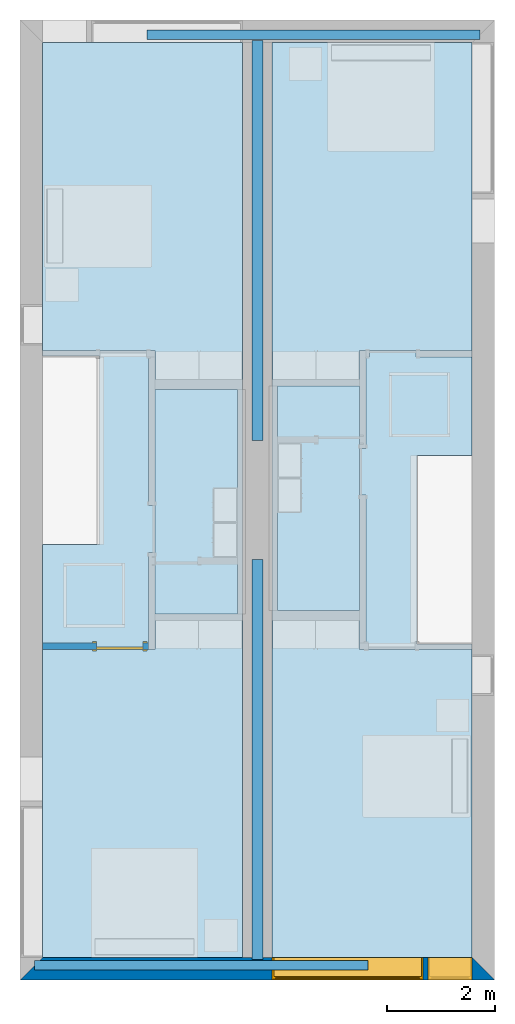
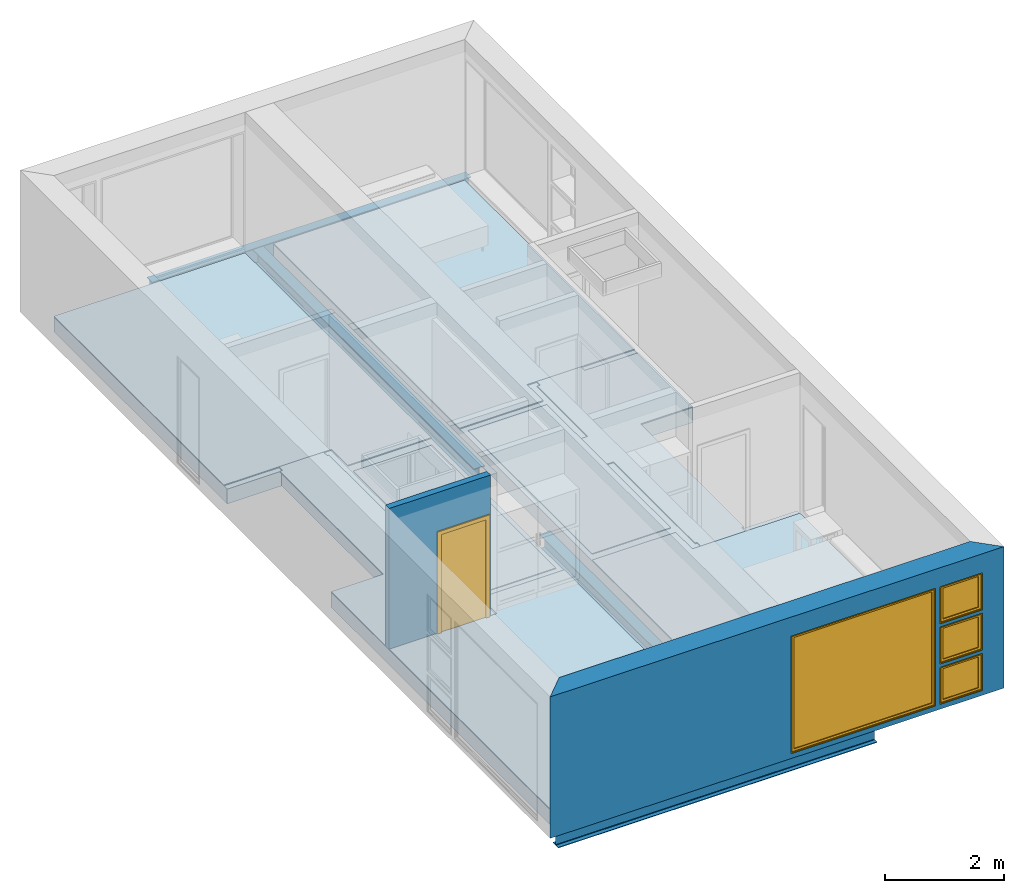
# One storey, part 1 of 10: 10 slabs, 4 beams, 4 windows, 2 walls, 1 door, 6 openings.
"""IFC2X3 building model written with IfcOpenShell, lengths in metres."""

from ifc_helpers import new_model, entity, si_unit, converted_unit, derived_unit, direction, frame, frame_2d, origin, origin_2d_with_axis, place, context, subcontext, project, spatial, polyline, rectangle, i_section, outline, extrude, source, transform, mapped, material, material_list, layer, layer_set, layer_usage, type_object, type_shapes, element, fill, save


model = new_model("IFC2X3")

# Units and contexts
model_context = context("Model", 3, precision=1e-05, world=origin(), true_north=direction((6.12303176911189e-17, 1.0)))
body_context = subcontext(model_context, "Body", "Model", "MODEL_VIEW")
ifc_project = project(units=[derived_unit("USERDEFINED", [(si_unit("LENGTHUNIT", "METRE"), -2), (si_unit("TIMEUNIT", "SECOND"), -2), (si_unit("MASSUNIT", "GRAM", prefix="KILO"), 1)]), si_unit("FREQUENCYUNIT", "HERTZ"), si_unit("LENGTHUNIT", "METRE"), si_unit("ILLUMINANCEUNIT", "LUX"), derived_unit("LINEARVELOCITYUNIT", [(si_unit("TIMEUNIT", "SECOND"), -1), (si_unit("LENGTHUNIT", "METRE"), 1)]), si_unit("POWERUNIT", "WATT"), si_unit("LUMINOUSINTENSITYUNIT", "CANDELA"), si_unit("AREAUNIT", "SQUARE_METRE"), si_unit("VOLUMEUNIT", "CUBIC_METRE"), si_unit("ELECTRICVOLTAGEUNIT", "VOLT"), si_unit("PRESSUREUNIT", "PASCAL"), converted_unit("PLANEANGLEUNIT", "DEGREE", entity("IfcRatioMeasure", 0.0174532925199433), si_unit("PLANEANGLEUNIT", "RADIAN"), dimensions=[0, 0, 0, 0, 0, 0, 0]), si_unit("THERMODYNAMICTEMPERATUREUNIT", "DEGREE_CELSIUS"), si_unit("MASSUNIT", "GRAM", prefix="KILO"), derived_unit("VOLUMETRICFLOWRATEUNIT", [(si_unit("LENGTHUNIT", "METRE"), 3), (si_unit("TIMEUNIT", "SECOND"), -1)]), si_unit("TIMEUNIT", "SECOND"), si_unit("LUMINOUSFLUXUNIT", "LUMEN"), derived_unit("USERDEFINED", [(si_unit("LUMINOUSFLUXUNIT", "LUMEN"), 1), (si_unit("TIMEUNIT", "SECOND"), 3), (si_unit("MASSUNIT", "GRAM", prefix="KILO"), -1), (si_unit("LENGTHUNIT", "METRE"), -2)]), si_unit("FORCEUNIT", "NEWTON", prefix="KILO"), si_unit("ELECTRICCURRENTUNIT", "AMPERE"), derived_unit("THERMALTRANSMITTANCEUNIT", [(si_unit("TIMEUNIT", "SECOND"), -3), (si_unit("THERMODYNAMICTEMPERATUREUNIT", "KELVIN"), -1), (si_unit("MASSUNIT", "GRAM", prefix="KILO"), 1)])], contexts=[model_context])

# Site, building, storey
site_placement = place(None, origin())
site = spatial("IfcSite", under=ifc_project, at=site_placement, CompositionType="ELEMENT")
building_placement = place(site_placement, origin())
building = spatial("IfcBuilding", under=site, at=building_placement, CompositionType="ELEMENT")
storey_placement = place(building_placement, frame((0.0, 0.0, 3.10000000000038)))
storey = spatial("IfcBuildingStorey", under=building, at=storey_placement, Name="Level 2", CompositionType="ELEMENT", Elevation=3.10000000000038)

# Beams
ifc_material_1 = material(Name="Metal - Steel - 345 MPa")
beam_1_placement = place(storey_placement, frame((4.4, -10.0, 0.0), z_axis=(0.0, 0.0, 1.0), x_axis=(0.0, -1.0, 0.0)))
element("IfcBeam", 1, at=beam_1_placement, inside=storey, material=ifc_material_1, context=body_context, shape_type="SweptSolid", body=[
    extrude(i_section(OverallWidth=0.203, OverallDepth=0.303, WebThickness=0.00750000000000972, FlangeThickness=0.0131000000000008, FilletRadius=0.0199000000000001, at=frame_2d((8.04911692853238e-16, 5.41233724504764e-16), x_axis=(0.0, 1.0))), frame((0.0, 0.0, -0.151500000000005), z_axis=(1.0, 0.0, 0.0), x_axis=(0.0, 0.0, -1.0)), (0.0, 0.0, 1.0), 7.42129999999997),
])
beam_2_placement = place(storey_placement, frame((0.266612879575042, -17.523, 0.0)))
element("IfcBeam", 2, at=beam_2_placement, inside=storey, material=ifc_material_1, context=body_context, shape_type="SweptSolid", body=[
    extrude(i_section(OverallWidth=0.178000000000018, OverallDepth=0.407, WebThickness=0.00769999999947201, FlangeThickness=0.0128000000000003, FilletRadius=0.017200000000001, at=frame_2d((0.0, -3.24740234702858e-15), x_axis=(0.0, 1.0))), frame((0.0, 0.0, -0.203500000000006), z_axis=(1.0, 0.0, 0.0), x_axis=(0.0, 0.0, -1.0)), (0.0, 0.0, 1.0), 6.18188712042496),
])
beam_3_placement = place(storey_placement, frame((4.40000000000001, -7.79999999999999, 0.0), z_axis=(0.0, 0.0, 1.0), x_axis=(0.0, 1.0, 0.0)))
element("IfcBeam", 3, at=beam_3_placement, inside=storey, material=ifc_material_1, context=body_context, shape_type="SweptSolid", body=[
    extrude(i_section(OverallWidth=0.203, OverallDepth=0.303, WebThickness=0.00749999999999992, FlangeThickness=0.0131000000000008, FilletRadius=0.0199000000000001, at=frame_2d((8.04911692853238e-16, -8.18789480661053e-16), x_axis=(0.0, 1.0))), frame((0.0, 0.0, -0.151500000000005), z_axis=(1.0, 0.0, 0.0), x_axis=(0.0, 0.0, -1.0)), (0.0, 0.0, 1.0), 7.42129999999997),
])
beam_4_placement = place(storey_placement, frame((8.53338712042499, -0.277000000000043, 0.0), z_axis=(0.0, 0.0, 1.0), x_axis=(-1.0, 0.0, 0.0)))
element("IfcBeam", 4, at=beam_4_placement, inside=storey, material=ifc_material_1, context=body_context, shape_type="SweptSolid", body=[
    extrude(i_section(OverallWidth=0.178000000000039, OverallDepth=0.407, WebThickness=0.00769999999893593, FlangeThickness=0.0128000000000003, FilletRadius=0.0171999999999996, at=frame_2d((0.0, 4.85722573273506e-17), x_axis=(0.0, 1.0))), frame((0.0, 0.0, -0.203500000000006), z_axis=(1.0, 0.0, 0.0), x_axis=(0.0, 0.0, -1.0)), (0.0, 0.0, 1.0), 6.18188712042496),
])

# Slabs
ifc_material_2 = material(Name="Wood - Sheathing - plywood")
ifc_layer_1 = layer(ifc_material_2, 0.019)
ifc_material_3 = material(Name="Wood - Dimensional Lumber")
ifc_layer_2 = layer(ifc_material_3, 0.286)
ifc_layer_set_1 = layer_set([ifc_layer_1, ifc_layer_2], Name="Sol:Residential - Wood Joist with")
ifc_layer_usage_1 = layer_usage(ifc_layer_set_1, "AXIS3", "POSITIVE", 0.0)
slab_1_placement = place(storey_placement, origin())
element("IfcSlab", 5, at=slab_1_placement, inside=storey, material=ifc_layer_usage_1, Name="Sol:Residential - Wood Joist with", ObjectType="Sol:Residential - Wood Joist with", PredefinedType="FLOOR", context=body_context, shape_type="SweptSolid", body=[
    extrude(outline(polyline([(-8.94324999999998, -1.1906), (-1.28525, -1.1906), (-1.28525000000001, -0.136199999999979), (2.20574999999999, -0.136199999999973), (2.20575, -1.1906), (8.02275, -1.1906), (8.02274999999998, 2.5174), (-8.94324999999999, 2.51739999999997), (-8.94324999999998, -1.1906)])), frame((1.6076, -8.43975, 0.0), z_axis=(0.0, 0.0, -1.0), x_axis=(0.0, 1.0, 0.0)), (0.0, 0.0, 1.0), 0.305),
])
ifc_layer_usage_2 = layer_usage(ifc_layer_set_1, "AXIS3", "POSITIVE", 0.0)
slab_2_placement = place(storey_placement, origin())
element("IfcSlab", 6, at=slab_2_placement, inside=storey, material=ifc_layer_usage_2, Name="Sol:Residential - Wood Joist with", ObjectType="Sol:Residential - Wood Joist with", PredefinedType="FLOOR", context=body_context, shape_type="SweptSolid", body=[
    extrude(outline(polyline([(-8.02274999999998, -2.52489999999999), (8.94324999999999, -2.52489999999999), (8.94324999999998, 1.18310000000001), (1.28525, 1.1831), (1.28525, 0.158699999999999), (-2.20574999999999, 0.158699999999993), (-2.20575, 1.18309999999999), (-8.02274999999999, 1.18309999999998), (-8.02274999999998, -2.52489999999999)])), frame((7.19989999999999, -9.36025, 0.0), z_axis=(0.0, 0.0, -1.0), x_axis=(0.0, 1.0, 0.0)), (0.0, 0.0, 1.0), 0.305),
])
ifc_material_4 = material(Name="Wood - Flooring")
ifc_layer_3 = layer(ifc_material_4, 0.016)
ifc_material_5 = material(Name="Insulation / Thermal Barriers - Semi-rigid insulation")
ifc_layer_4 = layer(ifc_material_5, 0.003)
ifc_layer_set_2 = layer_set([ifc_layer_3, ifc_layer_4], Name="Sol:Finish Floor - Wood")
ifc_layer_usage_3 = layer_usage(ifc_layer_set_2, "AXIS3", "POSITIVE", 0.0)
slab_3_placement = place(storey_placement, origin())
element("IfcSlab", 7, at=slab_3_placement, inside=storey, material=ifc_layer_usage_3, Name="Sol:Finish Floor - Wood", ObjectType="Sol:Finish Floor - Wood", PredefinedType="FLOOR", context=body_context, shape_type="SweptSolid", body=[
    extrude(outline(polyline([(-1.723, -1.93233333333333), (3.986, -1.93233333333333), (3.98599999999999, 1.77566666666667), (-2.263, 1.77566666666666), (-2.263, 0.156666666666669), (-1.723, 0.156666666666669), (-1.723, -1.93233333333333)])), frame((2.34933333333333, -4.403, 0.0189999999998181), z_axis=(0.0, 0.0, -1.0), x_axis=(0.0, 1.0, 0.0)), (0.0, 0.0, 1.0), 0.019),
])
ifc_layer_usage_4 = layer_usage(ifc_layer_set_2, "AXIS3", "POSITIVE", 0.0)
slab_4_placement = place(storey_placement, origin())
element("IfcSlab", 8, at=slab_4_placement, inside=storey, material=ifc_layer_usage_4, Name="Sol:Finish Floor - Wood", ObjectType="Sol:Finish Floor - Wood", PredefinedType="FLOOR", context=body_context, shape_type="SweptSolid", body=[
    extrude(outline(polyline([(-2.26299999999999, -1.77566666666667), (3.98599999999999, -1.77566666666667), (3.98599999999998, 1.93233333333333), (-1.723, 1.93233333333332), (-1.72299999999999, -0.156666666666655), (-2.26299999999999, -0.156666666666655), (-2.26299999999999, -1.77566666666667)])), frame((6.45066666666667, -4.40300000000001, 0.0189999999998181), z_axis=(0.0, 0.0, -1.0), x_axis=(0.0, 1.0, 0.0)), (0.0, 0.0, 1.0), 0.019),
])
ifc_layer_usage_5 = layer_usage(ifc_layer_set_2, "AXIS3", "POSITIVE", 0.0)
slab_5_placement = place(storey_placement, origin())
element("IfcSlab", 9, at=slab_5_placement, inside=storey, material=ifc_layer_usage_5, Name="Sol:Finish Floor - Wood", ObjectType="Sol:Finish Floor - Wood", PredefinedType="FLOOR", context=body_context, shape_type="SweptSolid", body=[
    extrude(outline(polyline([(-3.99133333333333, -1.77566666666668), (2.27366666666666, -1.77566666666668), (2.27366666666666, -0.156666666666648), (1.71766666666666, -0.156666666666647), (1.71766666666666, 1.93233333333334), (-3.99133333333333, 1.93233333333332), (-3.99133333333333, -1.77566666666668)])), frame((6.45066666666666, -13.3916666666667, 0.0189999999998181), z_axis=(0.0, 0.0, -1.0), x_axis=(0.0, 1.0, 0.0)), (0.0, 0.0, 1.0), 0.019),
])
ifc_layer_usage_6 = layer_usage(ifc_layer_set_2, "AXIS3", "POSITIVE", 0.0)
slab_6_placement = place(storey_placement, origin())
element("IfcSlab", 10, at=slab_6_placement, inside=storey, material=ifc_layer_usage_6, Name="Sol:Finish Floor - Wood", ObjectType="Sol:Finish Floor - Wood", PredefinedType="FLOOR", context=body_context, shape_type="SweptSolid", body=[
    extrude(outline(polyline([(-3.98599999999998, -1.93233333333333), (1.72299999999999, -1.93233333333333), (1.72299999999999, 0.156666666666671), (2.26299999999999, 0.156666666666671), (2.26299999999999, 1.77566666666667), (-3.98599999999999, 1.77566666666664), (-3.98599999999998, -1.93233333333333)])), frame((2.34933333333333, -13.397, 0.0189999999998181), z_axis=(0.0, 0.0, -1.0), x_axis=(0.0, 1.0, 0.0)), (0.0, 0.0, 1.0), 0.019),
])
ifc_layer_usage_7 = layer_usage(ifc_layer_set_2, "AXIS3", "POSITIVE", 0.0)
slab_7_placement = place(storey_placement, origin())
element("IfcSlab", 11, at=slab_7_placement, inside=storey, material=ifc_layer_usage_7, Name="Sol:Finish Floor - Wood", ObjectType="Sol:Finish Floor - Wood", PredefinedType="FLOOR", context=body_context, shape_type="SweptSolid", body=[
    extrude(outline(polyline([(-2.43876640477542, -1.43288888888889), (-0.613766404775426, -1.43288888888889), (-0.613766404775428, -0.418488888888887), (2.86123359522457, -0.418488888888879), (2.86123359522457, -0.366588888888892), (2.98523359522457, -0.366588888888891), (2.98523359522457, 0.497411111111109), (2.86123359522458, 0.497411111111109), (2.86123359522458, 0.532111111111114), (0.10518241671399, 0.532111111111114), (0.10518241671399, 0.656111111111112), (-0.758817583286009, 0.656111111111112), (-0.758817583286009, 0.532111111111114), (-2.43876640477542, 0.532111111111114), (-2.43876640477542, 0.432111111111106), (-2.56276640477543, 0.432111111111106), (-2.56276640477542, -0.431888888888894), (-2.43876640477542, -0.431888888888893), (-2.43876640477542, -1.43288888888889)])), frame((1.84988888888889, -9.11123359522458, 0.018999999999817), z_axis=(0.0, 0.0, -1.0), x_axis=(0.0, 1.0, 0.0)), (0.0, 0.0, 1.0), 0.019),
])
ifc_layer_usage_8 = layer_usage(ifc_layer_set_2, "AXIS3", "POSITIVE", 0.0)
slab_8_placement = place(storey_placement, origin())
element("IfcSlab", 12, at=slab_8_placement, inside=storey, material=ifc_layer_usage_8, Name="Sol:Finish Floor - Wood", ObjectType="Sol:Finish Floor - Wood", PredefinedType="FLOOR", context=body_context, shape_type="SweptSolid", body=[
    extrude(outline(polyline([(-0.117187738388962, -0.648244444444422), (0.746812261611036, -0.648244444444422), (0.746812261611037, -0.524244444444445), (2.44219649668256, -0.524244444444443), (2.44219649668256, -0.464244444444433), (2.56619649668256, -0.464244444444433), (2.56619649668256, 0.399755555555566), (2.44219649668256, 0.399755555555567), (2.44219649668255, 1.44075555555554), (0.617196496682559, 1.44075555555554), (0.617196496682562, 0.426355555555552), (-2.85780350331744, 0.426355555555541), (-2.85780350331744, 0.379055555555557), (-2.98180350331744, 0.379055555555557), (-2.98180350331743, -0.484944444444444), (-2.85780350331743, -0.484944444444443), (-2.85780350331743, -0.524244444444465), (-0.117187738388963, -0.524244444444463), (-0.117187738388962, -0.648244444444422)])), frame((6.94224444444443, -8.69219649668257, 0.018999999999817), z_axis=(0.0, 0.0, -1.0), x_axis=(0.0, 1.0, 0.0)), (0.0, 0.0, 1.0), 0.019),
])
ifc_material_6 = material(Name="Ceramic Tile")
ifc_layer_5 = layer(ifc_material_6, 0.01)
ifc_material_7 = material(Name="Masonry - Grout")
ifc_layer_6 = layer(ifc_material_7, 0.003)
ifc_layer_set_3 = layer_set([ifc_layer_5, ifc_layer_6], Name="Sol:Finish Floor - Ceramic Tile")
ifc_layer_usage_9 = layer_usage(ifc_layer_set_3, "AXIS3", "POSITIVE", 0.0)
slab_9_placement = place(storey_placement, origin())
element("IfcSlab", 13, at=slab_9_placement, inside=storey, material=ifc_layer_usage_9, Name="Sol:Finish Floor - Ceramic Tile", ObjectType="Sol:Finish Floor - Ceramic Tile", PredefinedType="FLOOR", context=body_context, shape_type="SweptSolid", body=[
    extrude(rectangle(XDim=4.16, YDim=1.52399999999999, at=frame_2d((0.0, 1.66533453693773e-15), x_axis=(1.0, 0.0))), frame((3.26799999999999, -8.93, 0.0129999999998178), z_axis=(0.0, 0.0, -1.0), x_axis=(0.0, 1.0, 0.0)), (0.0, 0.0, 1.0), 0.0129999999999998),
])
ifc_layer_usage_10 = layer_usage(ifc_layer_set_3, "AXIS3", "POSITIVE", 0.0)
slab_10_placement = place(storey_placement, origin())
element("IfcSlab", 14, at=slab_10_placement, inside=storey, material=ifc_layer_usage_10, Name="Sol:Finish Floor - Ceramic Tile", ObjectType="Sol:Finish Floor - Ceramic Tile", PredefinedType="FLOOR", context=body_context, shape_type="SweptSolid", body=[
    extrude(rectangle(XDim=4.16000000000001, YDim=1.52400000000001, at=frame_2d((1.11022302462516e-15, -2.77555756156289e-16), x_axis=(1.0, 0.0))), frame((5.53199999999999, -8.87000000000001, 0.0129999999998178), z_axis=(0.0, 0.0, -1.0), x_axis=(0.0, 1.0, 0.0)), (0.0, 0.0, 1.0), 0.0129999999999998),
])

# Wall, openings, windows
ifc_material_8 = material(Name="Masonry - Brick")
ifc_layer_7 = layer(ifc_material_8, 0.092)
ifc_material_9 = material(Name="Misc. Air Layers - Air Space")
ifc_layer_8 = layer(ifc_material_9, 0.025)
ifc_material_10 = material(Name="Insulation / Thermal Barriers - Rigid insulation")
ifc_layer_9 = layer(ifc_material_10, 0.05)
ifc_material_11 = material(Name="Masonry - Concrete Block")
ifc_layer_10 = layer(ifc_material_11, 0.193)
ifc_material_12 = material(Name="Metal - Stud Layer")
ifc_layer_11 = layer(ifc_material_12, 0.041)
ifc_material_13 = material(Name="Plasterboard")
ifc_layer_12 = layer(ifc_material_13, 0.016)
ifc_layer_set_4 = layer_set([ifc_layer_7, ifc_layer_8, ifc_layer_9, ifc_layer_10, ifc_layer_11, ifc_layer_12], Name="Mur de base:Exterior - Brick on Block")
ifc_layer_usage_11 = layer_usage(ifc_layer_set_4, "AXIS2", "NEGATIVE", 0.2085)
wall_type_1 = type_object("IfcWallType", Name="Mur de base:Exterior - Brick on Block", PredefinedType="STANDARD", material=ifc_layer_set_4)
wall_1_placement = place(storey_placement, frame((8.79999999999997, -17.5915, 0.0), z_axis=(0.0, 0.0, 1.0), x_axis=(-1.0, 0.0, 0.0)))
wall_1 = element("IfcWallStandardCase", 15, at=wall_1_placement, inside=storey, type_object=wall_type_1, material=ifc_layer_usage_11, Name="Mur de base:Exterior - Brick on Block", ObjectType="Mur de base:Exterior - Brick on Block", context=body_context, shape_type="SweptSolid", body=[
    extrude(outline(polyline([(8.38299999999997, -0.208499999999999), (8.79999999999997, 0.2085), (0.0, 0.2085), (0.417000000000003, -0.208500000000001), (4.125, -0.2085), (4.675, -0.2085), (8.38299999999997, -0.208499999999999)])), origin(), (0.0, 0.0, 1.0), 2.90000000000001),
])
opening_1_placement = place(wall_1_placement, origin())
element("IfcOpeningElement", 16, at=opening_1_placement, cuts=wall_1, Name="Mur de base:Exterior - Brick on Block", ObjectType="Opening", context=body_context, shape_type="SweptSolid", body=[
    extrude(rectangle(XDim=2.41, YDim=0.417, at=frame_2d((0.0, 0.0), x_axis=(0.0, 1.0))), frame((8.59149999999998, -3.0085, 1.305), z_axis=(0.0, 1.0, 0.0), x_axis=(-1.0, 0.0, 0.0)), (0.0, 0.0, 1.0), 2.8),
])
opening_2_placement = place(wall_1_placement, frame((0.417000000000017, -0.2085, 0.925499999999818)))
opening_2 = element("IfcOpeningElement", 17, at=opening_2_placement, cuts=wall_1, Name="M_Casement:819mm x 759mm:1", ObjectType="Opening", context=body_context, shape_type="SweptSolid", body=[
    extrude(rectangle(XDim=0.759000000000001, YDim=0.819, at=frame_2d((0.3795, 0.4095), x_axis=(-1.0, 0.0))), frame((0.0, 0.0, 0.0), z_axis=(0.0, 1.0, 0.0), x_axis=(0.0, 0.0, 1.0)), (0.0, 0.0, 1.0), 0.417),
])
opening_3_placement = place(wall_1_placement, frame((0.417, -0.208499999999999, 0.0999999999998235)))
opening_3 = element("IfcOpeningElement", 18, at=opening_3_placement, cuts=wall_1, Name="M_Fixed:819mm x 759mm:1", ObjectType="Opening", context=body_context, shape_type="SweptSolid", body=[
    extrude(rectangle(XDim=0.758999999999998, YDim=0.819, at=frame_2d((0.379499999999999, 0.4095), x_axis=(1.0, 0.0))), frame((0.0, 0.0, 0.0), z_axis=(0.0, 1.0, 0.0), x_axis=(0.0, 0.0, 1.0)), (0.0, 0.0, 1.0), 0.417),
])
opening_4_placement = place(wall_1_placement, frame((0.417, -0.208499999999999, 1.75099999999982)))
opening_4 = element("IfcOpeningElement", 19, at=opening_4_placement, cuts=wall_1, Name="M_Fixed:819mm x 759mm:1", ObjectType="Opening", context=body_context, shape_type="SweptSolid", body=[
    extrude(rectangle(XDim=0.758999999999998, YDim=0.819, at=frame_2d((0.379499999999999, 0.4095), x_axis=(1.0, 0.0))), frame((0.0, 0.0, 0.0), z_axis=(0.0, 1.0, 0.0), x_axis=(0.0, 0.0, 1.0)), (0.0, 0.0, 1.0), 0.417),
])
opening_5_placement = place(wall_1_placement, frame((1.325, -0.208499999999998, 0.099999999999823)))
opening_5 = element("IfcOpeningElement", 20, at=opening_5_placement, cuts=wall_1, Name="M_Fixed:2800mm x 2410mm:1", ObjectType="Opening", context=body_context, shape_type="SweptSolid", body=[
    extrude(rectangle(XDim=2.41, YDim=2.8, at=frame_2d((1.205, 1.4), x_axis=(1.0, 0.0))), frame((0.0, 0.0, 0.0), z_axis=(0.0, 1.0, 0.0), x_axis=(0.0, 0.0, 1.0)), (0.0, 0.0, 1.0), 0.417),
])
ifc_material_14 = material(Name="Glass")
ifc_material_15 = material(Name="Sash")
ifc_material_list_1 = material_list([ifc_material_14, ifc_material_15])
ifc_material_list_2 = material_list([ifc_material_14, ifc_material_15])
window_style_1 = type_object("IfcWindowStyle", Name="2800mm x 2410mm", ConstructionType="OTHER_CONSTRUCTION", OperationType="NOTDEFINED", ParameterTakesPrecedence=False, Sizeable=False, material=ifc_material_list_2)
shared_shape_1 = source(origin(), body_context, "Body", "SweptSolid", [
    extrude(outline(polyline([(-1.4, -1.205), (1.4, -1.205), (1.4, 1.205), (-1.4, 1.205), (-1.4, -1.205)]), holes=[polyline([(-1.368, -1.17299999999998), (-1.368, 1.17300000000002), (1.368, 1.17300000000002), (1.368, -1.17299999999998), (-1.368, -1.17299999999998)])]), frame((1.40000000000001, 0.0, 1.20500000000001), z_axis=(0.0, 1.0, 0.0), x_axis=(1.0, 0.0, 0.0)), (0.0, 0.0, 1.0), 0.353999999999973),
    extrude(rectangle(XDim=0.012, YDim=2.674, at=origin_2d_with_axis()), frame((1.40000000000001, 0.375999999999996, 0.0629999999999851), z_axis=(0.0, 0.0, 1.0), x_axis=(0.0, -1.0, 0.0)), (0.0, 0.0, 1.0), 2.284),
    extrude(outline(polyline([(-1.4, -1.205), (1.4, -1.205), (1.4, 1.205), (-1.4, 1.205), (-1.4, -1.205)]), holes=[polyline([(-1.381, -1.18599999999998), (-1.381, 1.18600000000002), (1.381, 1.18600000000002), (1.381, -1.18599999999998), (-1.381, -1.18599999999998)])]), frame((1.40000000000001, 0.353999999999968, 1.20500000000001), z_axis=(0.0, 1.0, 0.0), x_axis=(1.0, 0.0, 0.0)), (0.0, 0.0, 1.0), 0.0630000000000274),
    extrude(outline(polyline([(-1.381, -1.186), (1.381, -1.186), (1.381, 1.186), (-1.381, 1.186), (-1.381, -1.186)]), holes=[polyline([(-1.337, -1.142), (-1.337, 1.142), (1.337, 1.142), (1.337, -1.142), (-1.337, -1.142)])]), frame((1.40000000000001, 0.353999999999968, 1.20499999999999), z_axis=(0.0, 1.0, 0.0), x_axis=(1.0, 0.0, 0.0)), (0.0, 0.0, 1.0), 0.0440000000000274),
])
type_shapes(window_style_1, [shared_shape_1])
window_1_placement = place(opening_5_placement, origin())
window_1 = element("IfcWindow", 21, at=window_1_placement, inside=storey, type_object=window_style_1, material=ifc_material_list_1, Name="M_Fixed:2800mm x 2410mm", ObjectType="2800mm x 2410mm", OverallHeight=2.41, OverallWidth=2.8, context=body_context, shape_type="MappedRepresentation", body=[
    mapped(shared_shape_1, transform((0.0, 0.0, 0.0), scale=1.0)),
])
fill(opening_5, window_1)
ifc_material_list_3 = material_list([ifc_material_14, ifc_material_15])
ifc_material_list_4 = material_list([ifc_material_14, ifc_material_15])
window_style_2 = type_object("IfcWindowStyle", Name="819mm x 759mm", ConstructionType="OTHER_CONSTRUCTION", OperationType="NOTDEFINED", ParameterTakesPrecedence=False, Sizeable=False, material=ifc_material_list_4)
shared_shape_2 = source(origin(), body_context, "Body", "SweptSolid", [
    extrude(outline(polyline([(-0.4095, -0.379499999999997), (0.4095, -0.379499999999997), (0.4095, 0.379499999999997), (-0.4095, 0.379499999999997), (-0.4095, -0.379499999999997)]), holes=[polyline([(-0.390500000000001, -0.360499999999982), (-0.390500000000001, 0.360500000000023), (0.390499999999999, 0.360500000000023), (0.390499999999999, -0.360499999999982), (-0.390500000000001, -0.360499999999982)])]), frame((0.409500000000009, 0.353999999999971, 0.37950000000001), z_axis=(0.0, 1.0, 0.0), x_axis=(1.0, 0.0, 0.0)), (0.0, 0.0, 1.0), 0.0630000000000274),
    extrude(outline(polyline([(-0.4095, -0.379499999999997), (0.4095, -0.379499999999997), (0.4095, 0.379499999999997), (-0.4095, 0.379499999999997), (-0.4095, -0.379499999999997)]), holes=[polyline([(-0.3775, -0.347499999999983), (-0.3775, 0.347500000000021), (0.3775, 0.347500000000021), (0.3775, -0.347499999999983), (-0.3775, -0.347499999999983)])]), frame((0.40950000000001, 0.0, 0.379500000000009), z_axis=(0.0, 1.0, 0.0), x_axis=(1.0, 0.0, 0.0)), (0.0, 0.0, 1.0), 0.353999999999973),
    extrude(outline(polyline([(-0.3905, -0.360500000000003), (0.3905, -0.360500000000003), (0.3905, 0.360500000000003), (-0.3905, 0.360500000000003), (-0.3905, -0.360500000000003)]), holes=[polyline([(-0.3465, -0.316500000000003), (-0.3465, 0.316500000000004), (0.346499999999997, 0.316500000000004), (0.346499999999997, -0.316500000000003), (-0.3465, -0.316500000000003)])]), frame((0.409500000000008, 0.353999999999971, 0.379499999999989), z_axis=(0.0, 1.0, 0.0), x_axis=(1.0, 0.0, 0.0)), (0.0, 0.0, 1.0), 0.0440000000000274),
    extrude(rectangle(XDim=0.012, YDim=0.692999999999997, at=origin_2d_with_axis()), frame((0.409500000000007, 0.375999999999999, 0.0629999999999851), z_axis=(0.0, 0.0, 1.0), x_axis=(0.0, -1.0, 0.0)), (0.0, 0.0, 1.0), 0.633000000000007),
])
type_shapes(window_style_2, [shared_shape_2])
window_2_placement = place(opening_3_placement, origin())
window_2 = element("IfcWindow", 22, at=window_2_placement, inside=storey, type_object=window_style_2, material=ifc_material_list_3, Name="M_Fixed:819mm x 759mm", ObjectType="819mm x 759mm", OverallHeight=0.758999999999998, OverallWidth=0.819, context=body_context, shape_type="MappedRepresentation", body=[
    mapped(shared_shape_2, transform((0.0, 0.0, 0.0), scale=1.0)),
])
fill(opening_3, window_2)
ifc_material_list_5 = material_list([ifc_material_14, ifc_material_15])
window_3_placement = place(opening_4_placement, origin())
window_3 = element("IfcWindow", 23, at=window_3_placement, inside=storey, type_object=window_style_2, material=ifc_material_list_5, Name="M_Fixed:819mm x 759mm", ObjectType="819mm x 759mm", OverallHeight=0.758999999999998, OverallWidth=0.819, context=body_context, shape_type="MappedRepresentation", body=[
    mapped(shared_shape_2, transform((0.0, 0.0, 0.0), scale=1.0)),
])
fill(opening_4, window_3)
ifc_material_16 = material(Name="Trim")
ifc_material_list_6 = material_list([ifc_material_14, ifc_material_15, ifc_material_16])
ifc_material_list_7 = material_list([ifc_material_14, ifc_material_15, ifc_material_16])
window_style_3 = type_object("IfcWindowStyle", Name="819mm x 759mm", ConstructionType="OTHER_CONSTRUCTION", OperationType="NOTDEFINED", ParameterTakesPrecedence=False, Sizeable=False, material=ifc_material_list_7)
shared_shape_3 = source(origin(), body_context, "Body", "SweptSolid", [
    extrude(outline(polyline([(-0.390449999999999, -0.360450000000001), (0.390449999999999, -0.360450000000001), (0.390449999999999, 0.360450000000001), (-0.390449999999999, 0.360450000000001), (-0.390449999999999, -0.360450000000001)]), holes=[polyline([(-0.345999999999998, -0.316000000000002), (-0.345999999999998, 0.316000000000003), (0.346, 0.316000000000003), (0.346, -0.316000000000002), (-0.345999999999998, -0.316000000000002)])]), frame((0.409499999999999, 0.35355, 0.379500000000007), z_axis=(0.0, 1.0, 0.0), x_axis=(1.0, 0.0, 0.0)), (0.0, 0.0, 1.0), 0.04445),
    extrude(outline(polyline([(-0.379500000000002, -0.409499999999999), (0.379500000000002, -0.409499999999999), (0.379500000000002, 0.409499999999999), (-0.379500000000002, 0.409499999999999), (-0.379500000000002, -0.409499999999999)]), holes=[polyline([(-0.360450000000002, -0.390449999999999), (-0.360450000000002, 0.39045), (0.360450000000002, 0.39045), (0.360450000000002, -0.390449999999999), (-0.360450000000002, -0.390449999999999)])]), frame((0.4095, 0.35355, 0.379500000000007), z_axis=(0.0, 1.0, 0.0), x_axis=(0.0, 0.0, -1.0)), (0.0, 0.0, 1.0), 0.06345),
    extrude(rectangle(XDim=0.0127, YDim=0.691999999999998, at=frame_2d((-1.69135538907739e-17, 0.0), x_axis=(1.0, 0.0))), frame((0.4095, 0.375775, 0.063500000000004), z_axis=(0.0, 0.0, 1.0), x_axis=(0.0, 1.0, 0.0)), (0.0, 0.0, 1.0), 0.632000000000004),
    extrude(outline(polyline([(-0.409499999999999, -0.379500000000001), (0.409499999999999, -0.379500000000001), (0.409499999999999, 0.379500000000001), (-0.409499999999999, 0.379500000000001), (-0.409499999999999, -0.379500000000001)]), holes=[polyline([(-0.37775, -0.34775), (-0.37775, 0.347750000000001), (0.377749999999998, 0.347750000000001), (0.377749999999998, -0.34775), (-0.37775, -0.34775)])]), frame((0.409500000000001, 0.0, 0.379500000000008), z_axis=(0.0, 1.0, 0.0), x_axis=(1.0, 0.0, 0.0)), (0.0, 0.0, 1.0), 0.35355),
])
type_shapes(window_style_3, [shared_shape_3])
window_4_placement = place(opening_2_placement, origin())
window_4 = element("IfcWindow", 24, at=window_4_placement, inside=storey, type_object=window_style_3, material=ifc_material_list_6, Name="M_Casement:819mm x 759mm", ObjectType="819mm x 759mm", OverallHeight=0.759000000000001, OverallWidth=0.819, context=body_context, shape_type="MappedRepresentation", body=[
    mapped(shared_shape_3, transform((0.0, 0.0, 0.0), scale=1.0)),
])
fill(opening_2, window_4)

# Wall, opening, door
ifc_layer_13 = layer(ifc_material_13, 0.016)
ifc_layer_14 = layer(ifc_material_12, 0.092)
ifc_layer_15 = layer(ifc_material_13, 0.016)
ifc_layer_set_5 = layer_set([ifc_layer_13, ifc_layer_14, ifc_layer_15], Name="Mur de base:Interior - Partition (92mm Stud)")
ifc_layer_usage_12 = layer_usage(ifc_layer_set_5, "AXIS2", "NEGATIVE", 0.062)
wall_type_2 = type_object("IfcWallType", Name="Mur de base:Interior - Partition (92mm Stud)", PredefinedType="STANDARD", material=ifc_layer_set_5)
wall_2_placement = place(storey_placement, frame((2.38199999999999, -11.612, 0.0), z_axis=(0.0, 0.0, 1.0), x_axis=(-1.0, 0.0, 0.0)))
wall_2 = element("IfcWallStandardCase", 25, at=wall_2_placement, inside=storey, type_object=wall_type_2, material=ifc_layer_usage_12, Name="Mur de base:Interior - Partition (92mm Stud)", ObjectType="Mur de base:Interior - Partition (92mm Stud)", context=body_context, shape_type="SweptSolid", body=[
    extrude(rectangle(XDim=1.96499999999999, YDim=0.124000000000002, at=frame_2d((0.982499999999996, -1.35308431126191e-16), x_axis=(-1.0, 0.0))), origin(), (0.0, 0.0, 1.0), 2.90000000000001),
])
opening_6_placement = place(wall_2_placement, frame((0.0999999999999989, -0.0620000000000021, 0.0)))
opening_6 = element("IfcOpeningElement", 26, at=opening_6_placement, cuts=wall_2, Name="M_Single-Flush:0864 x 2032mm:1", ObjectType="Opening", context=body_context, shape_type="SweptSolid", body=[
    extrude(rectangle(XDim=0.863999999999999, YDim=2.032, at=frame_2d((1.016, 0.432), x_axis=(0.0, -1.0))), frame((0.0, 0.0, 0.0), z_axis=(0.0, 1.0, 0.0), x_axis=(0.0, 0.0, 1.0)), (0.0, 0.0, 1.0), 0.124),
])
ifc_material_17 = material(Name="Door - Frame")
ifc_material_18 = material(Name="Door - Panel")
ifc_material_list_8 = material_list([ifc_material_17, ifc_material_18])
ifc_material_list_9 = material_list([ifc_material_17, ifc_material_18])
door_style = type_object("IfcDoorStyle", Name="0864 x 2032mm", ConstructionType="USERDEFINED", OperationType="SINGLE_SWING_LEFT", ParameterTakesPrecedence=False, Sizeable=False, material=ifc_material_list_9)
shared_shape_4 = source(origin(), body_context, "Body", "SweptSolid", [
    extrude(outline(polyline([(-0.508, -1.073), (0.508, -1.073), (0.508, 1.035), (0.432, 1.035), (0.432, -0.997000000000002), (-0.432, -0.997000000000002), (-0.432, 1.035), (-0.508, 1.035), (-0.508, -1.073)])), frame((0.432, 0.148999999999988, 1.035), z_axis=(0.0, -1.0, 0.0), x_axis=(-1.0, 0.0, 0.0)), (0.0, 0.0, 1.0), 0.0249999999999944),
    extrude(outline(polyline([(-1.073, -0.507999999999997), (1.035, -0.507999999999997), (1.035, -0.432000000000007), (-0.997, -0.432000000000007), (-0.997, 0.432000000000002), (1.035, 0.432000000000002), (1.035, 0.508000000000003), (-1.073, 0.508000000000003), (-1.073, -0.507999999999997)])), frame((0.431999999999998, 0.0, 1.035), z_axis=(0.0, -1.0, 0.0), x_axis=(0.0, 0.0, -1.0)), (0.0, 0.0, 1.0), 0.0250000000000056),
    extrude(rectangle(XDim=0.864, YDim=0.051, at=frame_2d((0.0, 3.46944695195361e-18), x_axis=(1.0, 0.0))), frame((0.432, 0.0984999999999937, 0.0)), (0.0, 0.0, 1.0), 2.032),
])
type_shapes(door_style, [shared_shape_4])
door_placement = place(opening_6_placement, origin())
door = element("IfcDoor", 27, at=door_placement, inside=storey, type_object=door_style, material=ifc_material_list_8, Name="M_Single-Flush:0864 x 2032mm", ObjectType="0864 x 2032mm", OverallHeight=2.032, OverallWidth=0.864, context=body_context, shape_type="MappedRepresentation", body=[
    mapped(shared_shape_4, transform((0.0, 0.0, 0.0), scale=1.0)),
])
fill(opening_6, door)

save(model, "model.ifc")
